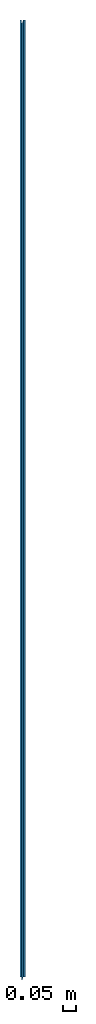
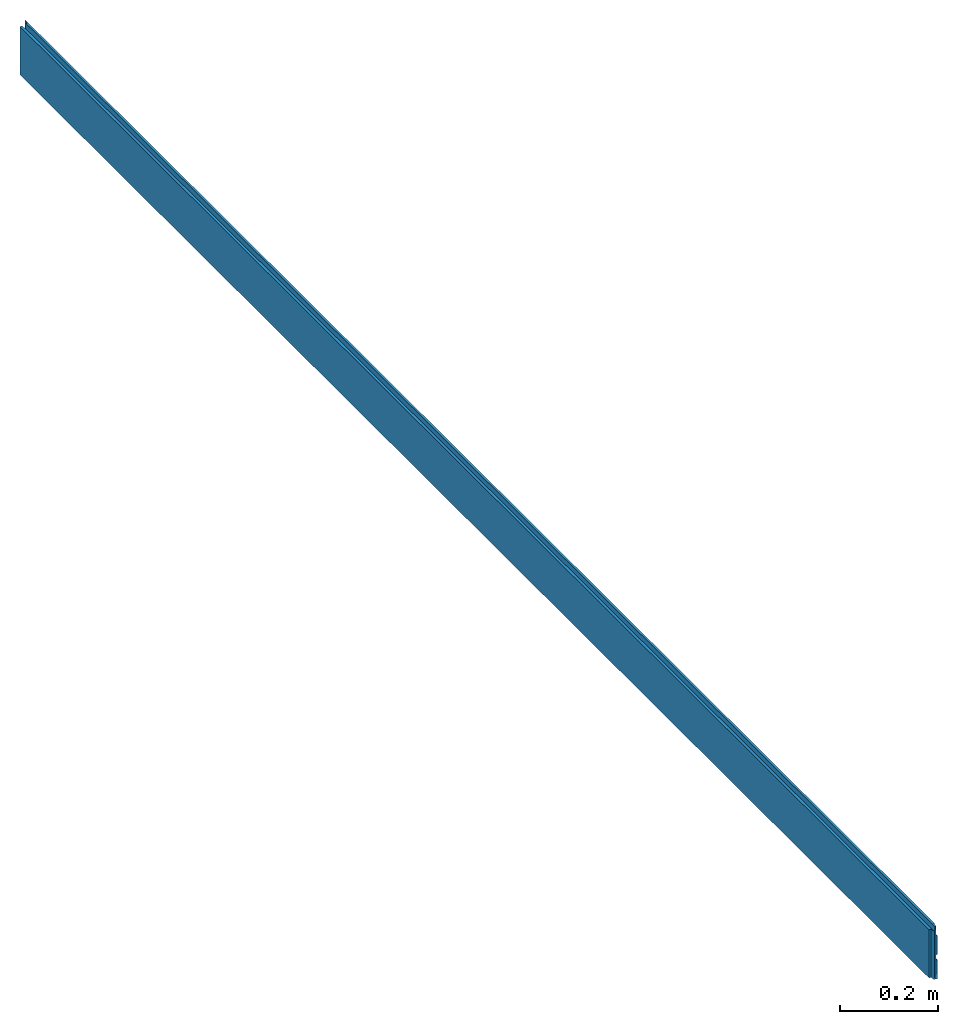
# One storey: 1 beam.
"""IFC2X3 building model written with IfcOpenShell, lengths in metres."""

from ifc_helpers import new_model, si_unit, frame, origin_with_axes, place, context, project, spatial, faceted_brep, material, element, save


model = new_model("IFC2X3")

# Units and contexts
model_context = context("Model", 3, precision=1e-06, world=origin_with_axes())
ifc_project = project(units=[si_unit("LENGTHUNIT", "METRE"), si_unit("PLANEANGLEUNIT", "RADIAN")], contexts=[model_context])

# Site, building, storey
site_placement = place(None, origin_with_axes())
site = spatial("IfcSite", under=ifc_project, at=site_placement, CompositionType="ELEMENT")
building_placement = place(None, origin_with_axes())
building = spatial("IfcBuilding", under=site, at=building_placement, Name="Building 1", CompositionType="ELEMENT")
storey_placement = place(None, origin_with_axes())
storey = spatial("IfcBuildingStorey", under=building, at=storey_placement, CompositionType="ELEMENT", Elevation=0.0)

# Beam
ifc_material = material()
beam_placement = place(None, frame((0.0105, -0.011500000000009, 0.061565277814696), z_axis=(0.0, 0.0, -1.0), x_axis=(0.0, 1.0, 0.0)))
element("IfcBeam", 1, at=beam_placement, inside=storey, material=ifc_material, context=model_context, shape_type="Brep", body=[
    faceted_brep([(3.710000000000033, 0.010499999999999, -0.035461599111857), (3.710000000000033, 0.010499999999999, 0.010434722185393), (3.711500000000033, 0.008999999999999, 0.010202736595956), (3.711500000000033, 0.008999999999999, -0.036350630650626), (3.710000000000033, 0.010499999999999, 0.024538400888143), (3.710000000000033, 0.010499999999999, 0.070434722185406), (3.711500000000033, 0.008999999999999, 0.070202596188963), (3.711500000000033, 0.008999999999999, 0.023649369349376), (3.711500000000033, 0.008999999999999, 0.070202596188963), (3.710000000000033, 0.010499999999999, 0.070434722185406), (0.013000000000006, 0.010499999999999, 0.070434722185406), (0.011500000000009, 0.009000000000003, 0.070202596188964), (0.011500000000009, 0.004189285714244, 0.069458134957507), (3.711500000000033, 0.004189285714244, 0.069458134957507), (3.711500000000033, 0.008999999999999, 0.023649369349376), (3.711500000000033, 0.008999999999999, 0.070202596188963), (3.711500000000033, 0.004189285714244, 0.069458134957507), (3.711500000000033, 0.002200000000081, 0.049565277814674), (3.711500000000033, 0.000698503731368, 0.049565277814659), (3.711500000000033, 0.000698503731368, -0.07043472218537), (3.711500000000033, 0.002200000000081, -0.070434722185355), (3.711500000000033, 0.004199999999957, -0.050434722185391), (3.711500000000033, 0.004199999999957, -0.039195531574713), (3.711500000000033, 0.008999999999999, -0.036350630650626), (3.711500000000033, 0.008999999999999, 0.010202736595956), (3.711500000000033, 0.004199999999957, 0.009460382709751), (3.711500000000033, 0.004199999999957, 0.020804468425295), (3.711500000000033, 0.008999999999999, 0.010202736595956), (3.710000000000033, 0.010499999999999, 0.010434722185393), (0.013000000000006, 0.010499999999999, 0.010434722185393), (0.011500000000009, 0.009000000000003, 0.010202736595956), (0.011500000000009, 0.004199999999957, 0.009460382709751), (3.711500000000033, 0.004199999999957, 0.009460382709751), (0.011500000000009, 0.009000000000003, -0.036350630650625), (0.011500000000009, 0.009000000000003, 0.010202736595956), (0.013000000000006, 0.010499999999999, 0.010434722185393), (0.01300000000001, 0.010500000000003, -0.035461599111855), (0.011500000000009, 0.009000000000003, 0.023649369349377), (0.011500000000009, 0.009000000000003, 0.070202596188964), (0.013000000000006, 0.010499999999999, 0.070434722185406), (0.01300000000001, 0.010500000000003, 0.024538400888145), (3.710000000000033, 0.010499999999999, 0.070434722185406), (3.710000000000033, 0.010499999999999, 0.024538400888143), (0.01300000000001, 0.010500000000003, 0.024538400888145), (0.013000000000006, 0.010499999999999, 0.070434722185406), (3.710000000000033, 0.010499999999999, 0.010434722185393), (3.710000000000033, 0.010499999999999, -0.035461599111857), (0.01300000000001, 0.010500000000003, -0.035461599111855), (0.013000000000006, 0.010499999999999, 0.010434722185393), (3.7, -0.000451496268546, -0.070434722185381), (3.7, -0.000451496268546, 0.049565277814648), (3.7, -0.003000000000005, 0.049565277814623), (3.7, -0.004199999999985, 0.061565277814718), (3.7, -0.004548503728394, 0.061565277814717), (3.7, -0.004548503728394, -0.058434722185333), (3.7, -0.004199999999985, -0.058434722185333), (3.7, -0.003000000000005, -0.070434722185406), (3.7, -0.004548503728394, -0.058434722185333), (3.7, -0.004548503728394, 0.061565277814717), (3.711500000000033, -0.005698503728364, 0.061565277814713), (3.711500000000033, -0.005698503728364, -0.058434722185333), (3.711500000000033, 0.000698503731368, -0.07043472218537), (3.711500000000033, 0.000698503731368, 0.049565277814659), (3.7, -0.000451496268546, 0.049565277814648), (3.7, -0.000451496268546, -0.070434722185381), (3.7, -0.003000000000005, -0.070434722185406), (3.7, -0.004199999999985, -0.058434722185333), (0.0, -0.004199999999985, -0.058434722185333), (0.0, -0.003000000000005, -0.070434722185406), (3.7, -0.004199999999985, -0.058434722185333), (3.7, -0.004548503728394, -0.058434722185333), (3.711500000000033, -0.005698503728364, -0.058434722185333), (3.711500000000033, -0.0105, -0.058434722185333), (0.011500000000009, -0.010499999999999, -0.058434722185333), (0.011500000000033, -0.005698503728363, -0.058434722185333), (0.0, -0.004548503728393, -0.058434722185333), (0.0, -0.004199999999985, -0.058434722185333), (3.711500000000033, -0.005698503728364, -0.058434722185333), (3.711500000000033, -0.005698503728364, 0.061565277814713), (3.711500000000033, -0.0105, 0.061565277814696), (3.711500000000033, -0.0105, -0.058434722185333), (3.711500000000033, -0.005698503728364, 0.061565277814713), (3.7, -0.004548503728394, 0.061565277814717), (3.7, -0.004199999999985, 0.061565277814718), (0.0, -0.004199999999985, 0.061565277814718), (0.0, -0.004548503728393, 0.061565277814717), (0.011500000000033, -0.005698503728363, 0.061565277814713), (0.011500000000009, -0.0105, 0.061565277814696), (3.711500000000033, -0.0105, 0.061565277814696), (0.011500000000033, -0.005698503728363, 0.061565277814713), (0.011500000000033, -0.005698503728363, -0.058434722185333), (0.011500000000009, -0.010499999999999, -0.058434722185333), (0.011500000000009, -0.0105, 0.061565277814696), (0.0, -0.004548503728393, 0.061565277814717), (0.0, -0.004548503728393, -0.058434722185333), (0.011500000000033, -0.005698503728363, -0.058434722185333), (0.011500000000033, -0.005698503728363, 0.061565277814713), (0.011500000000009, -0.0105, 0.061565277814696), (0.011500000000009, -0.010499999999999, -0.058434722185333), (3.711500000000033, -0.0105, -0.058434722185333), (3.711500000000033, -0.0105, 0.061565277814696), (0.011500000000009, 0.009000000000003, 0.070202596188964), (0.011500000000009, 0.009000000000003, 0.023649369349377), (0.011500000000009, 0.004199999999957, 0.020804468425295), (0.011500000000009, 0.004199999999957, 0.009460382709751), (0.011500000000009, 0.009000000000003, 0.010202736595956), (0.011500000000009, 0.009000000000003, -0.036350630650625), (0.011500000000009, 0.004199999999957, -0.039195531574713), (0.011500000000009, 0.004199999999957, -0.050434722185391), (0.011500000000009, 0.002200000000081, -0.070434722185355), (0.011500000000009, 0.000698503731373, -0.07043472218537), (0.011500000000009, 0.000698503731373, 0.049565277814659), (0.011500000000009, 0.002200000000081, 0.049565277814674), (0.011500000000009, 0.004189285714244, 0.069458134957507), (0.0, -0.000451496268545, -0.070434722185381), (0.0, -0.000451496268545, 0.049565277814648), (0.011500000000009, 0.000698503731373, 0.049565277814659), (0.011500000000009, 0.000698503731373, -0.07043472218537), (0.011500000000009, 0.004199999999957, -0.050434722185391), (0.011500000000009, 0.004199999999957, -0.039195531574713), (3.711500000000033, 0.004199999999957, -0.039195531574713), (3.711500000000033, 0.004199999999957, -0.050434722185391), (3.710000000000033, 0.010499999999999, -0.035461599111857), (3.711500000000033, 0.008999999999999, -0.036350630650626), (3.711500000000033, 0.004199999999957, -0.039195531574713), (0.011500000000009, 0.004199999999957, -0.039195531574713), (0.011500000000009, 0.009000000000003, -0.036350630650625), (0.01300000000001, 0.010500000000003, -0.035461599111855), (0.011500000000009, 0.004199999999957, 0.009460382709751), (0.011500000000009, 0.004199999999957, 0.020804468425295), (3.711500000000033, 0.004199999999957, 0.020804468425295), (3.711500000000033, 0.004199999999957, 0.009460382709751), (3.710000000000033, 0.010499999999999, 0.024538400888143), (3.711500000000033, 0.008999999999999, 0.023649369349376), (3.711500000000033, 0.004199999999957, 0.020804468425295), (0.011500000000009, 0.004199999999957, 0.020804468425295), (0.011500000000009, 0.009000000000003, 0.023649369349377), (0.01300000000001, 0.010500000000003, 0.024538400888145), (0.0, -0.004548503728393, -0.058434722185333), (0.0, -0.004548503728393, 0.061565277814717), (0.0, -0.004199999999985, 0.061565277814718), (0.0, -0.003000000000005, 0.049565277814623), (0.0, -0.000451496268545, 0.049565277814648), (0.0, -0.000451496268545, -0.070434722185381), (0.0, -0.003000000000005, -0.070434722185406), (0.0, -0.004199999999985, -0.058434722185333), (0.011500000000009, 0.002200000000081, -0.070434722185355), (0.011500000000009, 0.004199999999957, -0.050434722185391), (3.711500000000033, 0.004199999999957, -0.050434722185391), (3.711500000000033, 0.002200000000081, -0.070434722185355), (3.7, -0.000451496268546, -0.070434722185381), (3.7, -0.003000000000005, -0.070434722185406), (0.0, -0.003000000000005, -0.070434722185406), (0.0, -0.000451496268545, -0.070434722185381), (0.011500000000009, 0.000698503731373, -0.07043472218537), (0.011500000000009, 0.002200000000081, -0.070434722185355), (3.711500000000033, 0.002200000000081, -0.070434722185355), (3.711500000000033, 0.000698503731368, -0.07043472218537), (3.7, -0.004199999999985, 0.061565277814718), (3.7, -0.003000000000005, 0.049565277814623), (0.0, -0.003000000000005, 0.049565277814623), (0.0, -0.004199999999985, 0.061565277814718), (3.7, -0.000451496268546, 0.049565277814648), (3.711500000000033, 0.000698503731368, 0.049565277814659), (3.711500000000033, 0.002200000000081, 0.049565277814674), (0.011500000000009, 0.002200000000081, 0.049565277814674), (0.011500000000009, 0.000698503731373, 0.049565277814659), (0.0, -0.000451496268545, 0.049565277814648), (0.0, -0.003000000000005, 0.049565277814623), (3.7, -0.003000000000005, 0.049565277814623), (0.011500000000009, 0.004189285714244, 0.069458134957507), (0.011500000000009, 0.002200000000081, 0.049565277814674), (3.711500000000033, 0.002200000000081, 0.049565277814674), (3.711500000000033, 0.004189285714244, 0.069458134957507)], [[[0, 1, 2, 3]], [[4, 5, 6, 7]], [[8, 9, 10, 11, 12, 13]], [[14, 15, 16, 17, 18, 19, 20, 21, 22, 23, 24, 25, 26]], [[27, 28, 29, 30, 31, 32]], [[33, 34, 35, 36]], [[37, 38, 39, 40]], [[41, 42, 43, 44]], [[45, 46, 47, 48]], [[49, 50, 51, 52, 53, 54, 55, 56]], [[57, 58, 59, 60]], [[61, 62, 63, 64]], [[65, 66, 67, 68]], [[69, 70, 71, 72, 73, 74, 75, 76]], [[77, 78, 79, 80]], [[81, 82, 83, 84, 85, 86, 87, 88]], [[89, 90, 91, 92]], [[93, 94, 95, 96]], [[97, 98, 99, 100]], [[101, 102, 103, 104, 105, 106, 107, 108, 109, 110, 111, 112, 113]], [[114, 115, 116, 117]], [[118, 119, 120, 121]], [[122, 123, 124, 125, 126, 127]], [[128, 129, 130, 131]], [[132, 133, 134, 135, 136, 137]], [[138, 139, 140, 141, 142, 143, 144, 145]], [[146, 147, 148, 149]], [[150, 151, 152, 153, 154, 155, 156, 157]], [[158, 159, 160, 161]], [[162, 163, 164, 165, 166, 167, 168, 169]], [[170, 171, 172, 173]]]),
])

save(model, "model.ifc")
